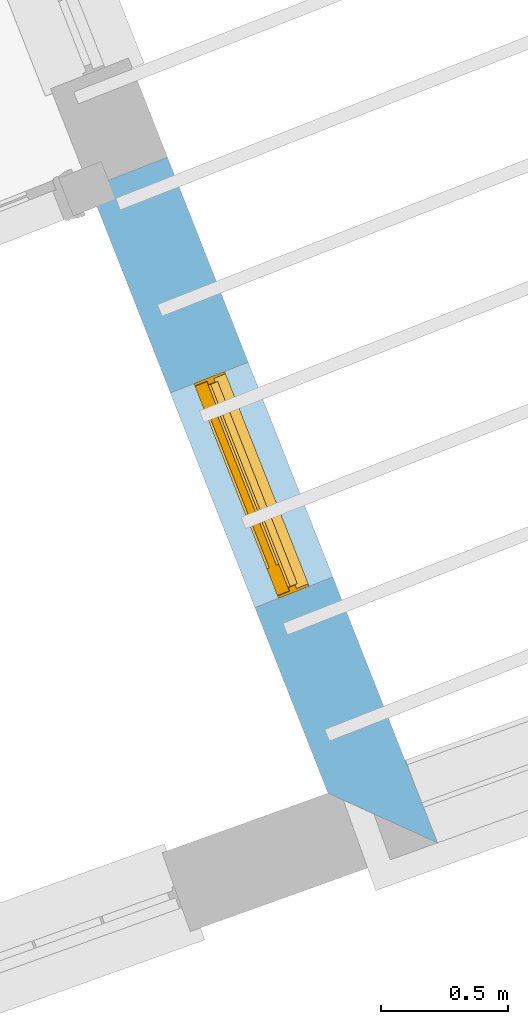
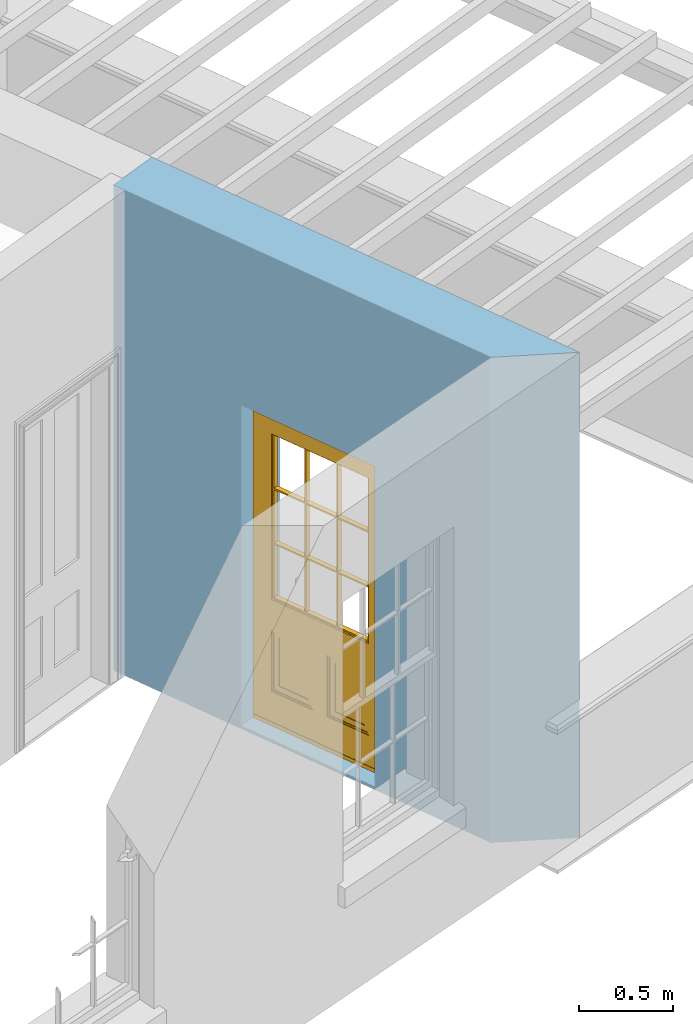
# One storey, part 6 of 8: 1 door, 1 opening, plus 1 element that does not belong to this part.
"""IFC2X3 building model written with IfcOpenShell, lengths in metres."""

from ifc_helpers import new_model, si_unit, frame, origin, place, context, subcontext, project, spatial, polyline, outline, extrude, faceted_brep, material, layer, layer_set, layer_usage, element, fill, save


model = new_model("IFC2X3")

# Units and contexts
model_context = context("Model", 3, world=origin())
body_context = subcontext(model_context, "Body", "Model", "MODEL_VIEW")
ifc_project = project(units=[si_unit("PLANEANGLEUNIT", "RADIAN"), si_unit("MASSUNIT", "GRAM", prefix="KILO"), si_unit("FORCEUNIT", "NEWTON", prefix="KILO"), si_unit("LENGTHUNIT", "METRE")], contexts=[model_context])

# Site, building, storey
site_placement = place(None, origin())
site = spatial("IfcSite", under=ifc_project, at=site_placement, CompositionType="ELEMENT")
building_placement = place(None, origin())
building = spatial("IfcBuilding", under=site, at=building_placement, Name="Building plot-4", CompositionType="ELEMENT")
storey_placement = place(None, frame((0.0, 0.0, 9.45)))
storey = spatial("IfcBuildingStorey", under=building, at=storey_placement, Name="Floor 2", CompositionType="ELEMENT", Elevation=9.45)

# Wall, opening, door
ifc_material = material(Name="Masonry")
ifc_layer = layer(ifc_material, 0.33, ventilated=False)
ifc_layer_set = layer_set([ifc_layer], Name="My Wall")
ifc_layer_usage = layer_usage(ifc_layer_set, "AXIS2", "NEGATIVE", 0.08)
wall_placement = place(storey_placement, origin())
wall = element("IfcWallStandardCase", 1, at=wall_placement, inside=storey, material=ifc_layer_usage, Name="exterior", context=body_context, shape_type="SweptSolid", body=[
    extrude(outline(polyline([(54.1548638616126, 48.176380175453), (54.5866021542831, 47.9806822762042), (53.5221730475567, 50.6835131799276), (53.2151257873123, 50.5625918006085), (54.1548638616126, 48.176380175453)])), origin(), (0.0, 0.0, 1.0), 3.15),
])
opening_placement = place(storey_placement, frame((0.0, 0.0, 0.0199999999999996)))
opening = element("IfcOpeningElement", 2, at=opening_placement, cuts=wall, Name="Opening", ObjectType="Opening", context=body_context, shape_type="SweptSolid", body=[
    extrude(outline(polyline([(54.1738810813349, 49.0286762323381), (53.8404312171518, 49.8753823136179), (53.5333839569074, 49.7544609342988), (53.8668338210905, 48.9077548530189), (54.1738810813349, 49.0286762323381)])), origin(), (0.0, 0.0, 1.0), 2.08),
])
door_placement = place(storey_placement, frame((53.9412695205437, 48.9370691267933, 0.0199999999999996), z_axis=(0.0, 0.0, 1.0), x_axis=(-0.333449864183123, 0.846706081279834, 0.0)))
door = element("IfcDoor", 3, at=door_placement, inside=storey, Name="circulation outside door", OverallHeight=2.08, OverallWidth=0.91, context=body_context, shape_type="Brep", held_by="IfcProductRepresentation", body=[
    faceted_brep([(0.545, -0.055, 0.265), (0.745, -0.055, 0.265), (0.745, -0.05, 0.265), (0.545, -0.05, 0.265), (0.745, -0.05, 0.58), (0.545, -0.05, 0.58), (0.545, -0.055, 0.58), (0.515, -0.06, 0.235), (0.775, -0.06, 0.235), (0.745, -0.055, 0.58), (0.515, -0.06, 0.61), (0.515, -0.065, 0.235), (0.775, -0.065, 0.235), (0.775, -0.06, 0.61), (0.515, -0.065, 0.61), (0.785, -0.065, 0.225), (0.505, -0.065, 0.225), (0.775, -0.065, 0.61), (0.505, -0.065, 0.62), (0.785, -0.065, 0.62), (0.505, -0.07, 0.225), (0.785, -0.07, 0.225), (0.505, -0.07, 0.62), (0.785, -0.07, 0.62), (0.883, -0.07, 0.075), (0.898, -0.07, 0.075), (0.405, -0.07, 0.62), (0.405, -0.07, 0.225), (0.027, -0.07, 0.075), (0.785, -0.07, 0.82), (0.125, -0.07, 0.82), (0.405, -0.065, 0.62), (0.405, -0.065, 0.225), (0.898, -0.07, 2.068), (0.027, -0.08, 0.075), (0.883, -0.08, 0.075), (0.125, -0.07, 0.225), (0.012, -0.07, 0.075), (0.785, -0.06, 0.82), (0.125, -0.06, 0.82), (0.125, -0.07, 0.62), (0.125, -0.065, 0.62), (0.395, -0.065, 0.61), (0.395, -0.065, 0.235), (0.125, -0.065, 0.225), (0.785, -0.07, 1.895), (0.027, -0.11, 0.045), (0.883, -0.11, 0.045), (0.558333, -0.06, 0.83), (0.351667, -0.06, 0.83), (0.125, -0.07, 1.895), (0.125, -0.06, 1.895), (0.785, -0.06, 1.895), (0.012, -0.07, 2.068), (0.135, -0.065, 0.61), (0.395, -0.06, 0.61), (0.395, -0.06, 0.235), (0.135, -0.065, 0.235), (0.027, -0.11, 0.027), (0.883, -0.11, 0.027), (0.568333, -0.06, 0.83), (0.558333, -0.03, 0.83), (0.351667, -0.03, 0.83), (0.341667, -0.06, 0.83), (0.135, -0.06, 1.185), (0.135, -0.06, 1.53), (0.775, -0.06, 1.53), (0.775, -0.06, 1.185), (0.135, -0.06, 0.61), (0.365, -0.055, 0.58), (0.365, -0.055, 0.265), (0.135, -0.06, 0.235), (0.568333, -0.06, 1.175), (0.558333, -0.06, 1.175), (0.775, -0.06, 0.83), (0.558333, -0.03, 1.175), (0.785, -0.03, 0.82), (0.125, -0.03, 0.82), (0.351667, -0.03, 1.175), (0.351667, -0.06, 1.175), (0.341667, -0.06, 1.175), (0.135, -0.06, 0.83), (0.135, -0.06, 1.175), (0.135, -0.03, 1.185), (0.135, -0.03, 1.53), (0.135, -0.06, 1.54), (0.351667, -0.06, 1.885), (0.558333, -0.06, 1.885), (0.775, -0.03, 1.53), (0.775, -0.03, 1.185), (0.775, -0.06, 1.175), (0.775, -0.06, 1.54), (0.165, -0.055, 0.58), (0.365, -0.05, 0.58), (0.365, -0.05, 0.265), (0.165, -0.055, 0.265), (0.568333, -0.03, 0.83), (0.568333, -0.03, 1.175), (0.568333, -0.06, 1.185), (0.558333, -0.06, 1.185), (0.775, -0.03, 0.83), (0.785, -0.02, 0.82), (0.125, -0.02, 0.82), (0.341667, -0.03, 0.83), (0.341667, -0.03, 1.175), (0.351667, -0.06, 1.185), (0.341667, -0.06, 1.185), (0.135, -0.03, 0.83), (0.341667, -0.03, 1.185), (0.125, -0.03, 1.895), (0.341667, -0.03, 1.53), (0.341667, -0.06, 1.53), (0.135, -0.06, 1.885), (0.341667, -0.06, 1.54), (0.341667, -0.06, 1.885), (0.558333, -0.03, 1.885), (0.351667, -0.03, 1.885), (0.568333, -0.06, 1.885), (0.785, -0.03, 1.895), (0.568333, -0.03, 1.185), (0.568333, -0.06, 1.53), (0.568333, -0.03, 1.53), (0.568333, -0.06, 1.54), (0.775, -0.06, 1.885), (0.165, -0.05, 0.58), (0.165, -0.05, 0.265), (0.775, -0.03, 1.175), (0.558333, -0.06, 1.53), (0.351667, -0.03, 1.185), (0.558333, -0.03, 1.185), (0.505, -0.02, 0.62), (0.405, -0.02, 0.62), (0.125, -0.02, 1.895), (0.785, -0.02, 1.895), (0.351667, -0.06, 1.53), (0.135, -0.03, 1.175), (0.135, -0.03, 1.54), (0.341667, -0.03, 1.54), (0.135, -0.03, 1.885), (0.351667, -0.06, 1.54), (0.558333, -0.03, 1.54), (0.558333, -0.06, 1.54), (0.351667, -0.03, 1.54), (0.775, -0.03, 1.54), (0.568333, -0.03, 1.54), (0.775, -0.03, 1.885), (0.558333, -0.03, 1.53), (0.405, -0.02, 0.225), (0.505, -0.02, 0.225), (0.125, -0.02, 0.62), (0.785, -0.02, 0.62), (0.012, -0.02, 2.068), (0.898, -0.02, 2.068), (0.351667, -0.03, 1.53), (0.341667, -0.03, 1.885), (0.568333, -0.03, 1.885), (0.405, -0.025, 0.225), (0.405, -0.025, 0.62), (0.505, -0.025, 0.62), (0.505, -0.025, 0.225), (0.898, -0.02, 0.027), (0.012, -0.02, 0.027), (0.125, -0.025, 0.62), (0.785, -0.025, 0.62), (0.395, -0.025, 0.235), (0.395, -0.025, 0.61), (0.125, -0.02, 0.225), (0.125, -0.025, 0.225), (0.515, -0.025, 0.61), (0.515, -0.025, 0.235), (0.785, -0.02, 0.225), (0.785, -0.025, 0.225), (0.135, -0.025, 0.61), (0.775, -0.025, 0.61), (0.135, -0.025, 0.235), (0.395, -0.03, 0.235), (0.395, -0.03, 0.61), (0.515, -0.03, 0.61), (0.515, -0.03, 0.235), (0.775, -0.025, 0.235), (0.135, -0.03, 0.61), (0.775, -0.03, 0.61), (0.135, -0.03, 0.235), (0.365, -0.035, 0.265), (0.365, -0.035, 0.58), (0.545, -0.035, 0.58), (0.545, -0.035, 0.265), (0.775, -0.03, 0.235), (0.165, -0.035, 0.58), (0.745, -0.035, 0.58), (0.165, -0.035, 0.265), (0.365, -0.04, 0.58), (0.365, -0.04, 0.265), (0.545, -0.04, 0.58), (0.545, -0.04, 0.265), (0.745, -0.035, 0.265), (0.165, -0.04, 0.58), (0.745, -0.04, 0.58), (0.165, -0.04, 0.265), (0.745, -0.04, 0.265), (0.885, -0.072, 0.025), (0.025, -0.072, 0.025), (0.025, -0.1, 0.025), (0.885, -0.1, 0.025), (0.9, -0.02, 0.025), (0.01, -0.02, 0.025), (0.9, -0.072, 0.025), (0.91, -0.02, 0.0), (0.0, -0.02, 0.0), (0.01, -0.072, 0.025), (0.9, -0.072, 2.07), (0.9, -0.02, 2.07), (0.885, -0.072, 2.055), (0.91, -0.02, 2.08), (0.01, -0.02, 2.07), (0.0, -0.02, 2.08), (0.01, -0.072, 2.07), (0.025, -0.072, 2.055), (0.0, -0.15, 2.08), (0.91, -0.15, 2.08), (0.01, -0.15, 2.07), (0.9, -0.15, 2.07), (0.01, -0.1, 2.07), (0.9, -0.1, 2.07), (0.0, -0.15, 0.0), (0.91, -0.15, 0.0), (0.01, -0.15, 0.025), (0.9, -0.15, 0.025), (0.01, -0.1, 0.025), (0.025, -0.1, 2.055), (0.9, -0.1, 0.025), (0.885, -0.1, 2.055), (0.898, -0.07, 0.027), (0.012, -0.07, 0.027), (0.883, -0.07, 0.027), (0.027, -0.07, 0.027)], [[[0, 1, 2, 3]], [[2, 4, 5, 3]], [[0, 3, 5, 6]], [[1, 0, 7, 8]], [[9, 4, 2, 1]], [[9, 6, 5, 4]], [[0, 6, 10, 7]], [[8, 7, 11, 12]], [[8, 13, 9, 1]], [[13, 10, 6, 9]], [[7, 10, 14, 11]], [[15, 12, 11, 16]], [[12, 17, 13, 8]], [[17, 14, 10, 13]], [[18, 16, 11, 14]], [[15, 19, 17, 12]], [[15, 16, 20, 21]], [[14, 17, 19, 18]], [[16, 18, 22, 20]], [[21, 23, 19, 15]], [[24, 25, 21, 20]], [[23, 22, 18, 19]], [[20, 22, 26, 27]], [[23, 21, 25]], [[28, 24, 20, 27]], [[22, 23, 29]], [[29, 30, 26, 22]], [[27, 26, 31, 32]], [[23, 25, 33, 29]], [[34, 35, 24, 28]], [[28, 27, 36, 37]], [[38, 39, 30, 29]], [[26, 30, 40]], [[26, 40, 41, 31]], [[42, 43, 32, 31]], [[32, 44, 36, 27]], [[33, 45, 29]], [[46, 47, 35, 34]], [[36, 40, 37]], [[39, 38, 48, 49]], [[50, 30, 39, 51]], [[29, 45, 52, 38]], [[53, 37, 40, 30]], [[44, 41, 40, 36]], [[31, 41, 54, 42]], [[43, 42, 55, 56]], [[57, 44, 32, 43]], [[50, 45, 33, 53]], [[47, 46, 58, 59]], [[60, 48, 38]], [[49, 48, 61, 62]], [[49, 63, 39]], [[50, 53, 30]], [[51, 39, 64, 65]], [[45, 50, 51, 52]], [[66, 67, 38, 52]], [[57, 54, 41, 44]], [[42, 54, 68, 55]], [[56, 55, 69, 70]], [[56, 71, 57, 43]], [[60, 72, 73, 48]], [[60, 38, 74]], [[48, 73, 75, 61]], [[76, 77, 62, 61]], [[62, 78, 79, 49]], [[49, 79, 80, 63]], [[63, 81, 39]], [[82, 64, 39]], [[65, 64, 83, 84]], [[85, 51, 65]], [[52, 51, 86, 87]], [[88, 89, 67, 66]], [[90, 38, 67]], [[91, 66, 52]], [[71, 68, 54, 57]], [[55, 68, 92, 69]], [[69, 93, 94, 70]], [[70, 95, 71, 56]], [[96, 97, 72, 60]], [[73, 72, 98, 99]], [[74, 38, 90]], [[100, 96, 60, 74]], [[75, 73, 79, 78]], [[61, 75, 97, 96]], [[101, 102, 77, 76]], [[77, 103, 62]], [[96, 76, 61]], [[103, 104, 78, 62]], [[80, 79, 105, 106]], [[63, 80, 104, 103]], [[81, 63, 103, 107]], [[81, 82, 39]], [[106, 64, 82, 80]], [[106, 108, 83, 64]], [[84, 83, 77, 109]], [[110, 111, 65, 84]], [[112, 51, 85]], [[113, 85, 65, 111]], [[114, 86, 51]], [[115, 87, 86, 116]], [[117, 52, 87]], [[118, 76, 89, 88]], [[119, 98, 67, 89]], [[120, 121, 88, 66]], [[67, 98, 72, 90]], [[91, 122, 120, 66]], [[91, 52, 123]], [[95, 92, 68, 71]], [[69, 92, 124, 93]], [[94, 93, 124, 125]], [[94, 125, 95, 70]], [[72, 97, 126, 90]], [[127, 99, 98, 120]], [[99, 105, 79, 73]], [[74, 90, 126, 100]], [[96, 100, 76]], [[128, 129, 75, 78]], [[97, 75, 129, 119]], [[130, 131, 102, 101]], [[109, 77, 102, 132]], [[133, 101, 76, 118]], [[77, 107, 103]], [[78, 104, 108, 128]], [[111, 106, 105, 134]], [[104, 80, 82, 135]], [[107, 135, 82, 81]], [[110, 108, 106, 111]], [[104, 135, 83, 108]], [[83, 135, 77]], [[136, 84, 109]], [[110, 84, 136, 137]], [[114, 51, 112]], [[85, 136, 138, 112]], [[113, 137, 136, 85]], [[111, 134, 139, 113]], [[86, 114, 113, 139]], [[140, 141, 87, 115]], [[139, 142, 116, 86]], [[109, 118, 115, 116]], [[117, 123, 52]], [[117, 87, 141, 122]], [[126, 89, 76]], [[143, 118, 88]], [[120, 98, 119, 121]], [[119, 89, 126, 97]], [[144, 143, 88, 121]], [[144, 122, 91, 143]], [[127, 120, 122, 141]], [[143, 91, 123, 145]], [[124, 92, 95, 125]], [[146, 129, 99, 127]], [[99, 129, 128, 105]], [[100, 126, 76]], [[121, 119, 129, 146]], [[147, 131, 130, 148]], [[131, 149, 102]], [[130, 101, 150]], [[102, 151, 132]], [[118, 109, 132, 133]], [[101, 133, 152]], [[107, 77, 135]], [[153, 128, 108, 110]], [[134, 105, 128, 153]], [[109, 138, 136]], [[153, 110, 137, 142]], [[154, 114, 112, 138]], [[137, 113, 114, 154]], [[141, 139, 134, 127]], [[141, 140, 142, 139]], [[144, 140, 115, 155]], [[142, 137, 154, 116]], [[155, 115, 118]], [[116, 154, 109]], [[117, 155, 145, 123]], [[122, 144, 155, 117]], [[143, 145, 118]], [[121, 146, 140, 144]], [[146, 127, 134, 153]], [[156, 157, 131, 147]], [[148, 130, 158, 159]], [[148, 160, 161, 147]], [[157, 162, 149, 131]], [[161, 151, 102, 149]], [[101, 152, 160, 150]], [[163, 158, 130, 150]], [[151, 152, 133, 132]], [[154, 138, 109]], [[142, 140, 146, 153]], [[145, 155, 118]], [[157, 156, 164, 165]], [[147, 166, 167, 156]], [[168, 169, 159, 158]], [[170, 148, 159, 171]], [[148, 170, 160]], [[166, 147, 161]], [[172, 162, 157, 165]], [[166, 149, 162, 167]], [[166, 161, 149]], [[150, 160, 170]], [[163, 173, 168, 158]], [[171, 163, 150, 170]], [[174, 164, 156, 167]], [[175, 176, 165, 164]], [[169, 168, 177, 178]], [[171, 159, 169, 179]], [[167, 162, 172, 174]], [[176, 180, 172, 165]], [[179, 173, 163, 171]], [[181, 177, 168, 173]], [[164, 174, 182, 175]], [[183, 184, 176, 175]], [[178, 177, 185, 186]], [[179, 169, 178, 187]], [[174, 172, 180, 182]], [[184, 188, 180, 176]], [[187, 181, 173, 179]], [[189, 185, 177, 181]], [[175, 182, 190, 183]], [[191, 184, 183, 192]], [[185, 193, 194, 186]], [[187, 178, 186, 195]], [[182, 180, 188, 190]], [[191, 196, 188, 184]], [[195, 189, 181, 187]], [[197, 193, 185, 189]], [[183, 190, 198, 192]], [[198, 196, 191, 192]], [[194, 193, 197, 199]], [[195, 186, 194, 199]], [[188, 196, 198, 190]], [[197, 189, 195, 199]], [[200, 201, 202, 203]], [[201, 200, 204, 205]], [[206, 204, 200]], [[204, 207, 208, 205]], [[209, 201, 205]], [[210, 211, 204, 206]], [[206, 200, 212, 210]], [[211, 213, 207, 204]], [[214, 205, 208, 215]], [[216, 217, 201, 209]], [[205, 214, 216, 209]], [[216, 214, 211, 210]], [[210, 212, 217, 216]], [[214, 215, 213, 211]], [[218, 219, 213, 215]], [[219, 218, 220, 221]], [[221, 220, 222, 223]], [[215, 208, 224, 218]], [[225, 224, 208, 207]], [[224, 226, 220, 218]], [[224, 225, 227, 226]], [[219, 225, 207, 213]], [[228, 222, 220, 226]], [[219, 221, 227, 225]], [[226, 227, 203, 202]], [[202, 229, 222, 228]], [[228, 226, 202]], [[227, 221, 223, 230]], [[230, 203, 227]], [[217, 229, 202, 201]], [[231, 223, 222, 229]], [[230, 223, 231, 203]], [[231, 229, 217, 212]], [[212, 200, 203, 231]], [[33, 152, 151, 53]], [[25, 160, 152, 33]], [[161, 37, 53, 151]], [[232, 160, 25]], [[161, 233, 37]], [[160, 232, 234]], [[24, 234, 232, 25]], [[233, 161, 235]], [[37, 233, 235, 28]], [[161, 160, 234, 235]], [[35, 47, 234, 24]], [[28, 235, 46, 34]], [[58, 235, 234, 59]], [[59, 234, 47]], [[58, 46, 235]]]),
])
fill(opening, door)

save(model, "model.ifc")
